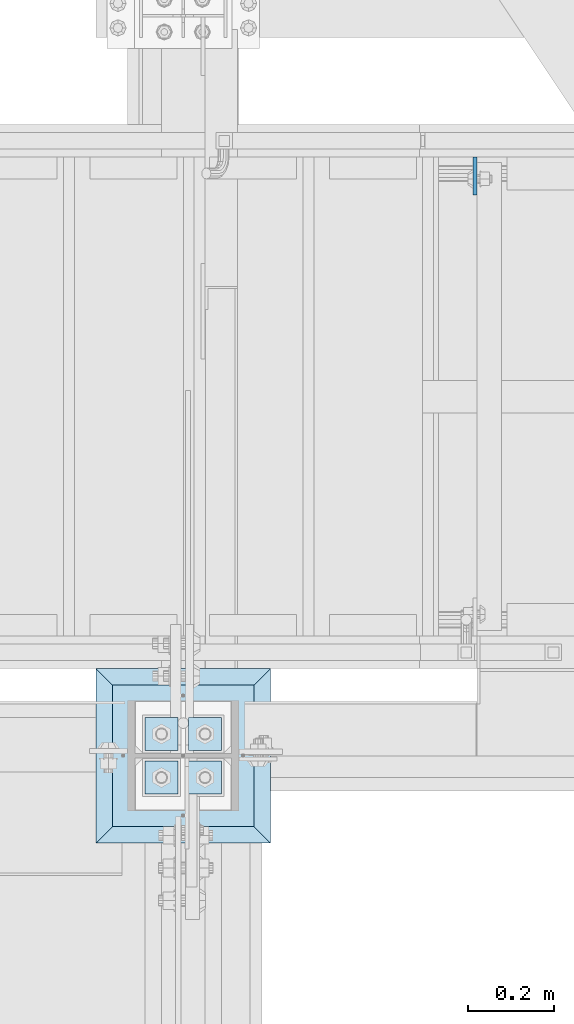
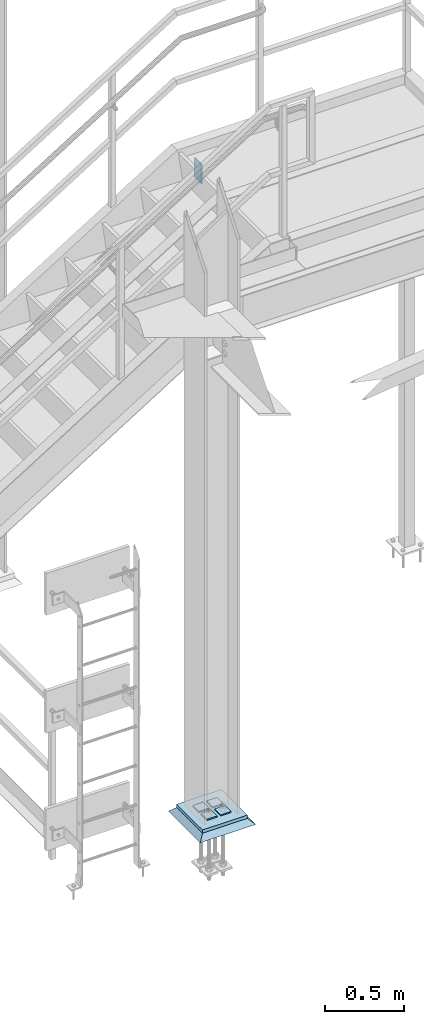
# One storey, part 3409 of 3843: 7 plates, 4 elements without a shape of their own.
"""IFC2X3 building model written with IfcOpenShell, lengths in millimetres."""

from ifc_helpers import new_model, si_unit, frame, origin_with_axes, place, context, subcontext, project, spatial, faceted_brep, material, type_object, element, aggregate, save


model = new_model("IFC2X3")

# Units and contexts
model_context = context("Model", 3, precision=1e-05, world=origin_with_axes())
body_context = subcontext(model_context, "Body", "Model", "MODEL_VIEW")
ifc_project = project(units=[si_unit("LENGTHUNIT", "METRE", prefix="MILLI"), si_unit("AREAUNIT", "SQUARE_METRE"), si_unit("VOLUMEUNIT", "CUBIC_METRE"), si_unit("MASSUNIT", "GRAM", prefix="KILO"), si_unit("TIMEUNIT", "SECOND"), si_unit("PLANEANGLEUNIT", "RADIAN"), si_unit("SOLIDANGLEUNIT", "STERADIAN"), si_unit("THERMODYNAMICTEMPERATUREUNIT", "DEGREE_CELSIUS"), si_unit("LUMINOUSINTENSITYUNIT", "LUMEN")], contexts=[model_context])

# Site, building, storey
site_placement = place(None, origin_with_axes())
site = spatial("IfcSite", under=ifc_project, at=site_placement, CompositionType="ELEMENT")
building_placement = place(site_placement, origin_with_axes())
building = spatial("IfcBuilding", under=site, at=building_placement, Name="Undefined", CompositionType="ELEMENT")
storey_placement = place(building_placement, origin_with_axes())
storey = spatial("IfcBuildingStorey", under=building, at=storey_placement, Name="Undefined", CompositionType="ELEMENT", Elevation=0.0)

# Assembly, plate
assembly_1_placement = place(storey_placement, origin_with_axes())
assembly_1 = element("IfcElementAssembly", 1, at=assembly_1_placement, inside=storey, Name="STAIR", AssemblyPlace="NOTDEFINED", PredefinedType="RIGID_FRAME")
ifc_material_1 = material(Name="STEEL/A36")
plate_type_1 = type_object("IfcPlateType", PredefinedType="NOTDEFINED")
plate_1_placement = place(assembly_1_placement, frame((37257.0374999897, 90512.9000000963, 34061.4000000121), z_axis=(0.0, -1.0, 0.0), x_axis=(0.0, 0.0, -1.0)))
plate_1 = element("IfcPlate", 2, at=plate_1_placement, type_object=plate_type_1, material=ifc_material_1, Name="PLATE", context=body_context, shape_type="Brep", body=[
    faceted_brep([(0.0, -4.76249999999709, 0.0), (0.0, -4.76249999999709, 88.9000015258789), (0.0, 4.76249999999709, 88.9000015258789), (0.0, 4.76249999999709, 0.0), (152.399993896484, -4.76249999999709, 88.9000015258789), (152.399993896484, 4.76249999999709, 88.9000015258789), (152.399993896484, -4.76249999999709, 0.0), (152.399993896484, 4.76249999999709, 0.0)], [[[0, 1, 2, 3]], [[1, 4, 5, 2]], [[4, 6, 7, 5]], [[6, 0, 3, 7]], [[5, 7, 3, 2]], [[6, 4, 1, 0]]]),
])
aggregate(assembly_1, [plate_1])

# Assembly, plates
assembly_2_placement = place(storey_placement, origin_with_axes())
assembly_2 = element("IfcElementAssembly", 3, at=assembly_2_placement, inside=storey, Name="TEMPLATE", AssemblyPlace="NOTDEFINED", PredefinedType="RIGID_FRAME")
ifc_material_2 = material(Name="STEEL/A572-50")
plate_type_2 = type_object("IfcPlateType", PredefinedType="NOTDEFINED")
plate_2_placement = place(assembly_2_placement, frame((36588.7, 89103.2, 30091.0625), z_axis=(0.0, -1.0, 0.0), x_axis=(1.0, 0.0, 0.0)))
plate_2 = element("IfcPlate", 4, at=plate_2_placement, type_object=plate_type_2, material=ifc_material_2, Name="Washer Plate", context=body_context, shape_type="Brep", body=[
    faceted_brep([(0.0, -4.76249999999709, 0.0), (-3.49245965480804e-10, -4.76249999999709, 76.1999999999462), (-3.49245965480804e-10, 4.76249999999709, 76.1999999999462), (0.0, 4.76249999999709, 0.0), (76.1999893188477, -4.76249999999709, 76.1999969482422), (76.1999893188477, 4.76249999999709, 76.1999969482422), (76.2000000012922, -4.76250000000073, 7.27595761418343e-11), (76.2000000012922, 4.76250000000073, 7.27595761418343e-11)], [[[0, 1, 2, 3]], [[1, 4, 5, 2]], [[4, 6, 7, 5]], [[6, 0, 3, 7]], [[5, 7, 3, 2]], [[6, 4, 1, 0]]]),
])
plate_3_placement = place(assembly_2_placement, frame((36588.7, 89204.8, 30091.0625), z_axis=(0.0, -1.0, 0.0), x_axis=(1.0, 0.0, 0.0)))
plate_3 = element("IfcPlate", 5, at=plate_3_placement, type_object=plate_type_2, material=ifc_material_2, Name="Washer Plate", context=body_context, shape_type="Brep", body=[
    faceted_brep([(0.0, -4.76249999999709, 0.0), (-3.49245965480804e-10, -4.76249999999709, 76.1999999999462), (-3.49245965480804e-10, 4.76249999999709, 76.1999999999462), (0.0, 4.76249999999709, 0.0), (76.1999893188477, -4.76249999999709, 76.1999969482422), (76.1999893188477, 4.76249999999709, 76.1999969482422), (76.2000000012922, -4.76250000000073, 7.27595761418343e-11), (76.2000000012922, 4.76250000000073, 7.27595761418343e-11)], [[[0, 1, 2, 3]], [[1, 4, 5, 2]], [[4, 6, 7, 5]], [[6, 0, 3, 7]], [[5, 7, 3, 2]], [[6, 4, 1, 0]]]),
])
plate_4_placement = place(assembly_2_placement, frame((36487.1, 89103.2, 30091.0625), z_axis=(0.0, -1.0, 0.0), x_axis=(1.0, 0.0, 0.0)))
plate_4 = element("IfcPlate", 6, at=plate_4_placement, type_object=plate_type_2, material=ifc_material_2, Name="Washer Plate", context=body_context, shape_type="Brep", body=[
    faceted_brep([(0.0, -4.76249999999709, 0.0), (-3.49245965480804e-10, -4.76249999999709, 76.1999999999462), (-3.49245965480804e-10, 4.76249999999709, 76.1999999999462), (0.0, 4.76249999999709, 0.0), (76.1999893188477, -4.76249999999709, 76.1999969482422), (76.1999893188477, 4.76249999999709, 76.1999969482422), (76.2000000012922, -4.76250000000073, 7.27595761418343e-11), (76.2000000012922, 4.76250000000073, 7.27595761418343e-11)], [[[0, 1, 2, 3]], [[1, 4, 5, 2]], [[4, 6, 7, 5]], [[6, 0, 3, 7]], [[5, 7, 3, 2]], [[6, 4, 1, 0]]]),
])
plate_5_placement = place(assembly_2_placement, frame((36487.1, 89204.8, 30091.0625), z_axis=(0.0, -1.0, 0.0), x_axis=(1.0, 0.0, 0.0)))
plate_5 = element("IfcPlate", 7, at=plate_5_placement, type_object=plate_type_2, material=ifc_material_2, Name="Washer Plate", context=body_context, shape_type="Brep", body=[
    faceted_brep([(0.0, -4.76249999999709, 0.0), (-3.49245965480804e-10, -4.76249999999709, 76.1999999999462), (-3.49245965480804e-10, 4.76249999999709, 76.1999999999462), (0.0, 4.76249999999709, 0.0), (76.1999893188477, -4.76249999999709, 76.1999969482422), (76.1999893188477, 4.76249999999709, 76.1999969482422), (76.2000000012922, -4.76250000000073, 7.27595761418343e-11), (76.2000000012922, 4.76250000000073, 7.27595761418343e-11)], [[[0, 1, 2, 3]], [[1, 4, 5, 2]], [[4, 6, 7, 5]], [[6, 0, 3, 7]], [[5, 7, 3, 2]], [[6, 4, 1, 0]]]),
])
aggregate(assembly_2, [plate_2, plate_3, plate_4, plate_5])

# Assembly, plate
assembly_3_placement = place(storey_placement, origin_with_axes())
assembly_3 = element("IfcElementAssembly", 8, at=assembly_3_placement, inside=storey, Name="COLUMN", AssemblyPlace="NOTDEFINED", PredefinedType="RIGID_FRAME")
plate_type_3 = type_object("IfcPlateType", PredefinedType="NOTDEFINED")
plate_6_placement = place(assembly_3_placement, frame((36410.9, 88950.8, 30073.6), z_axis=(0.0, 1.0, 0.0), x_axis=(1.0, 0.0, 0.0)))
plate_6 = element("IfcPlate", 9, at=plate_6_placement, type_object=plate_type_3, material=ifc_material_2, Name="PLATE", context=body_context, shape_type="Brep", body=[
    faceted_brep([(0.0, -12.6999999999971, 0.0), (0.0, -12.6999999999825, 330.199999999997), (-1.45519152283669e-11, 12.699999999968, 330.199999999997), (0.0, 12.6999999999971, 0.0), (330.200012207031, -12.7000000000007, 330.200012207031), (330.200012207031, 12.7000000000007, 330.200012207031), (330.200012207031, -12.7000000000007, 0.0), (330.200012207031, 12.7000000000007, 0.0)], [[[0, 1, 2, 3]], [[1, 4, 5, 2]], [[4, 6, 7, 5]], [[6, 0, 3, 7]], [[5, 7, 3, 2]], [[6, 4, 1, 0]]]),
])
aggregate(assembly_3, [plate_6])

assembly_4_placement = place(storey_placement, origin_with_axes())
assembly_4 = element("IfcElementAssembly", 10, at=assembly_4_placement, inside=storey, Name="GROUT", AssemblyPlace="NOTDEFINED", PredefinedType="REINFORCEMENT_UNIT")
ifc_material_3 = material(Name="CONCRETE/Concrete_Undefined")
plate_type_4 = type_object("IfcPlateType", PredefinedType="NOTDEFINED")
plate_7_placement = place(assembly_4_placement, frame((36372.8, 88912.7, 30041.85), z_axis=(0.0, 1.0, 0.0), x_axis=(1.0, 0.0, 0.0)))
plate_7 = element("IfcPlate", 11, at=plate_7_placement, type_object=plate_type_4, material=ifc_material_3, Name="GROUT", context=body_context, shape_type="Brep", body=[
    faceted_brep([(38.1000000006916, -19.0499999997883, 368.299999999334), (0.0, 19.0499999999993, 406.399993896484), (0.0, 19.0500000000029, 0.0), (38.1000000006916, -19.0499999999811, 38.1000000006607), (368.299999999343, -19.049999999821, 38.1000000006607), (406.399993896484, 19.0499999999993, 0.0), (406.399993896484, 19.0499999999993, 406.399993896484), (368.299999999343, -19.0499999999811, 368.299999999334)], [[[0, 1, 2, 3]], [[4, 5, 6, 7]], [[4, 7, 0, 3]], [[5, 4, 3, 2]], [[6, 5, 2, 1]], [[7, 6, 1, 0]]]),
])
aggregate(assembly_4, [plate_7])

save(model, "model.ifc")
